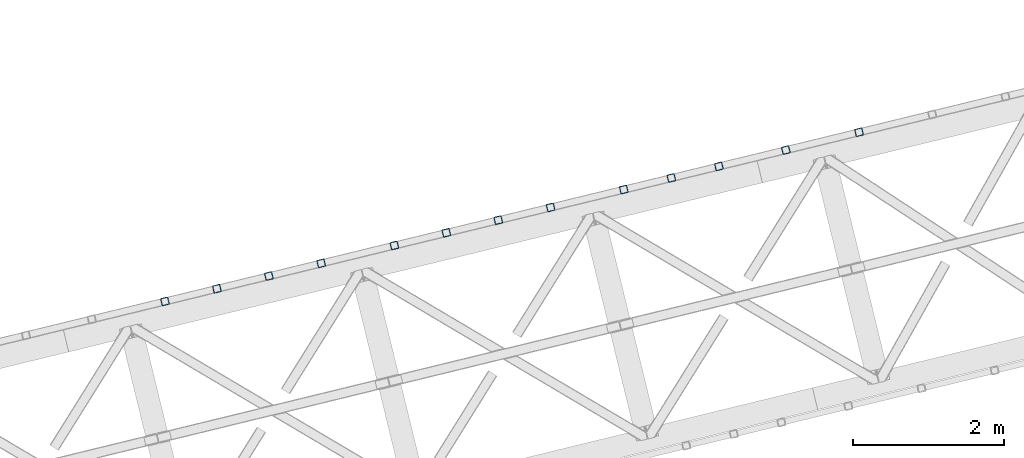
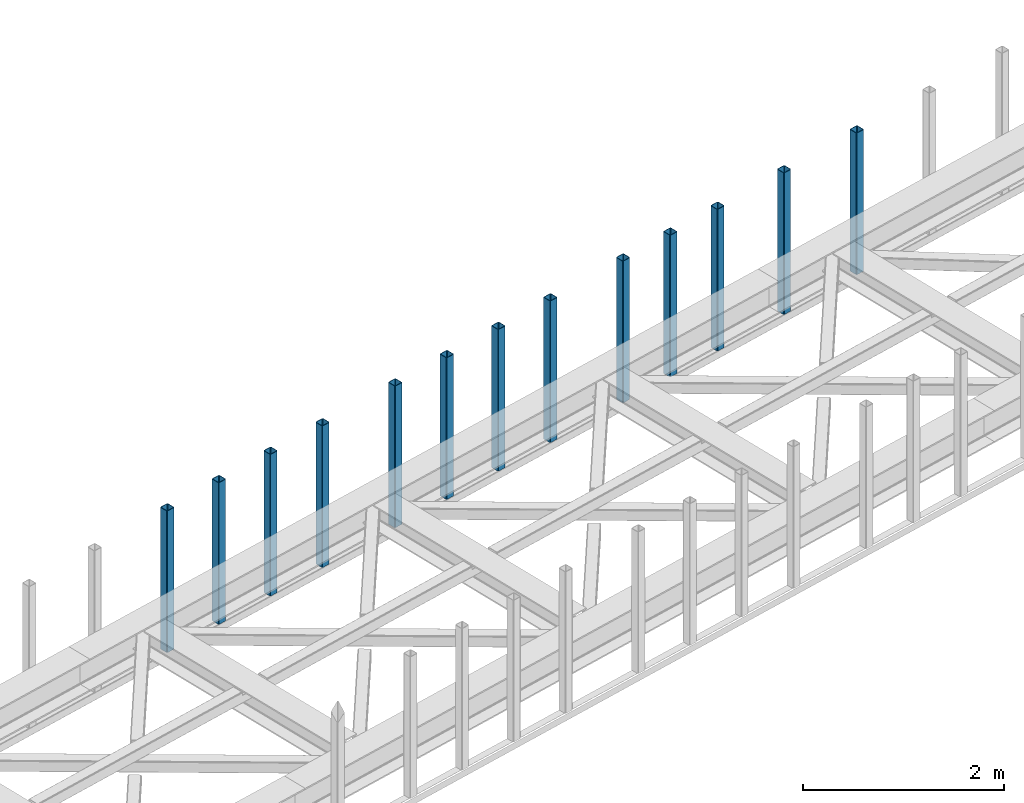
# One storey, part 10 of 67: 13 columns.
"""IFC4 building model written with IfcOpenShell, lengths in millimetres."""

from ifc_helpers import new_model, entity, si_unit, converted_unit, derived_unit, direction, frame, origin, place, context, subcontext, project, spatial, indexed_curve, outline, extrude, type_object, element, save


model = new_model("IFC4")

# Units and contexts
model_context = context("Model", 3, precision=0.01, world=origin(), true_north=direction((6.12303176911189e-17, 1.0)))
plan_context = context("Plan", 3, precision=0.01, world=origin(), true_north=direction((6.12303176911189e-17, 1.0)))
body_context = subcontext(model_context, "Body", "Model", "MODEL_VIEW")
ifc_project = project(units=[si_unit("LENGTHUNIT", "METRE", prefix="MILLI"), si_unit("AREAUNIT", "SQUARE_METRE"), si_unit("VOLUMEUNIT", "CUBIC_METRE"), converted_unit("PLANEANGLEUNIT", "DEGREE", entity("IfcRatioMeasure", 0.0174532925199433), si_unit("PLANEANGLEUNIT", "RADIAN"), dimensions=[0, 0, 0, 0, 0, 0, 0]), si_unit("MASSUNIT", "GRAM", prefix="KILO"), derived_unit("MASSDENSITYUNIT", [(si_unit("MASSUNIT", "GRAM", prefix="KILO"), 1), (si_unit("LENGTHUNIT", "METRE"), -3)]), derived_unit("MOMENTOFINERTIAUNIT", [(si_unit("LENGTHUNIT", "METRE"), 4)]), si_unit("TIMEUNIT", "SECOND"), si_unit("FREQUENCYUNIT", "HERTZ"), si_unit("THERMODYNAMICTEMPERATUREUNIT", "DEGREE_CELSIUS"), derived_unit("THERMALTRANSMITTANCEUNIT", [(si_unit("MASSUNIT", "GRAM", prefix="KILO"), 1), (si_unit("THERMODYNAMICTEMPERATUREUNIT", "KELVIN"), -1), (si_unit("TIMEUNIT", "SECOND"), -3)]), derived_unit("VOLUMETRICFLOWRATEUNIT", [(si_unit("LENGTHUNIT", "METRE"), 3), (si_unit("TIMEUNIT", "SECOND"), -1)]), derived_unit("MASSFLOWRATEUNIT", [(si_unit("MASSUNIT", "GRAM", prefix="KILO"), 1), (si_unit("TIMEUNIT", "SECOND"), -1)]), derived_unit("ROTATIONALFREQUENCYUNIT", [(si_unit("TIMEUNIT", "SECOND"), -1)]), si_unit("ELECTRICCURRENTUNIT", "AMPERE"), si_unit("ELECTRICVOLTAGEUNIT", "VOLT"), si_unit("POWERUNIT", "WATT"), si_unit("FORCEUNIT", "NEWTON", prefix="KILO"), si_unit("ILLUMINANCEUNIT", "LUX"), si_unit("LUMINOUSFLUXUNIT", "LUMEN"), si_unit("LUMINOUSINTENSITYUNIT", "CANDELA"), derived_unit("USERDEFINED", [(si_unit("MASSUNIT", "GRAM", prefix="KILO"), -1), (si_unit("LENGTHUNIT", "METRE"), -2), (si_unit("TIMEUNIT", "SECOND"), 3), (si_unit("LUMINOUSFLUXUNIT", "LUMEN"), 1)]), derived_unit("LINEARVELOCITYUNIT", [(si_unit("LENGTHUNIT", "METRE"), 1), (si_unit("TIMEUNIT", "SECOND"), -1)]), si_unit("PRESSUREUNIT", "PASCAL"), derived_unit("USERDEFINED", [(si_unit("LENGTHUNIT", "METRE"), -2), (si_unit("MASSUNIT", "GRAM", prefix="KILO"), 1), (si_unit("TIMEUNIT", "SECOND"), -2)]), derived_unit("LINEARFORCEUNIT", [(si_unit("MASSUNIT", "GRAM", prefix="KILO"), 1), (si_unit("LENGTHUNIT", "METRE"), 1), (si_unit("TIMEUNIT", "SECOND"), -2), (si_unit("LENGTHUNIT", "METRE"), -1)]), derived_unit("PLANARFORCEUNIT", [(si_unit("MASSUNIT", "GRAM", prefix="KILO"), 1), (si_unit("LENGTHUNIT", "METRE"), 1), (si_unit("TIMEUNIT", "SECOND"), -2), (si_unit("LENGTHUNIT", "METRE"), -2)])], contexts=[model_context, plan_context])

# Site, building, storey
site_placement = place(None, origin())
site = spatial("IfcSite", under=ifc_project, at=site_placement, CompositionType="ELEMENT")
building_placement = place(site_placement, origin())
building = spatial("IfcBuilding", under=site, at=building_placement, CompositionType="ELEMENT")
storey_placement = place(building_placement, frame((0.0, 0.0, 19800.0)))
storey = spatial("IfcBuildingStorey", under=building, at=storey_placement, CompositionType="ELEMENT", Elevation=19800.0)

# Columns
column_type_1 = type_object("IfcColumnType", PredefinedType="COLUMN")
column_1_placement = place(storey_placement, origin())
element("IfcColumn", 1, at=column_1_placement, inside=storey, type_object=column_type_1, ObjectType="Steel Column", PredefinedType="COLUMN", context=body_context, shape_type="SweptSolid", body=[
    extrude(outline(indexed_curve([(29.4768951153467, -56.8428769007942), (33.3787015556676, -56.8428769007942), (36.983500665698, -55.3497202197836), (39.7424944585306, -52.5907264269563), (41.2356511395342, -48.9859273169203), (56.8428769008001, 29.4768951153439), (56.842876900801, 33.3787015556669), (55.3497202197894, 36.9835006657001), (52.5907264269631, 39.7424944585298), (48.985927316928, 41.2356511395354), (-29.4768951153342, 56.8428769008003), (-33.3787015556561, 56.8428769007984), (-36.9835006657031, 55.3497202197932), (-39.7424944585171, 52.5907264269595), (-41.2356511395314, 48.9859273169262), (-56.8428769007964, -29.476895115336), (-56.8428769007886, -33.3787015556607), (-55.3497202197934, -36.9835006656934), (-52.5907264269506, -39.7424944585237), (-48.9859273169156, -41.2356511395292), (29.4768951153467, -56.8428769007942)], self_intersect=False), holes=[indexed_curve([(-43.1065493048213, -37.3071763475937), (-46.7113484148592, -35.8140196665892), (-49.4703422076954, -33.0550258737549), (-50.9634988886935, -29.4502267637184), (-50.9634988887002, -25.5484203234015), (-37.3071763475881, 43.1065493048283), (-35.8140196665894, 46.7113484148641), (-33.0550258737608, 49.4703422076981), (-29.4502267637207, 50.9634988887041), (-25.5484203233977, 50.9634988887032), (43.1065493048309, 37.3071763475988), (46.711348414863, 35.8140196665923), (49.470342207696, 33.0550258737666), (50.9634988887067, 29.4502267637314), (50.9634988887049, 25.5484203234065), (37.3071763475917, -43.1065493048204), (35.8140196665904, -46.7113484148669), (33.0550258737586, -49.4703422076875), (29.4502267637282, -50.9634988886981), (25.5484203234112, -50.9634988886999), (-43.1065493048213, -37.3071763475937)], self_intersect=False)]), frame((-11274.8424574772, 18249.8419278918, 3378.0), z_axis=(0.0, 0.0, 1.0), x_axis=(0.906681479027445, 0.4218159498983, 0.0)), (0.0, 0.0, 1.0), 1720.00000000001),
])
column_type_2 = type_object("IfcColumnType", PredefinedType="COLUMN")
column_2_placement = place(storey_placement, origin())
element("IfcColumn", 2, at=column_2_placement, inside=storey, type_object=column_type_2, ObjectType="Steel Column", PredefinedType="COLUMN", context=body_context, shape_type="SweptSolid", body=[
    extrude(outline(indexed_curve([(29.476895115345, -56.8428769008029), (33.378701555666, -56.8428769008029), (36.9835006657051, -55.3497202197941), (39.7424944585289, -52.590726426965), (41.2356511395325, -48.9859273169291), (56.8428769007984, 29.4768951153351), (56.8428769007993, 33.3787015556581), (55.3497202197965, 36.9835006656896), (52.5907264269614, 39.7424944585211), (48.9859273169264, 41.2356511395266), (-29.4768951153447, 56.8428769007933), (-33.3787015556666, 56.8428769007913), (-36.983500665696, 55.3497202197827), (-39.7424944585188, 52.5907264269508), (-41.2356511395331, 48.9859273169175), (-56.8428769007981, -29.4768951153448), (-56.8428769007903, -33.3787015556695), (-55.3497202197883, -36.983500665703), (-52.5907264269611, -39.7424944585308), (-48.9859273169261, -41.2356511395363), (29.476895115345, -56.8428769008029)], self_intersect=False), holes=[indexed_curve([(-43.106549304823, -37.3071763476025), (-46.7113484148609, -35.814019666598), (-49.4703422076892, -33.0550258737674), (-50.9634988886969, -29.450226763736), (-50.9634988886931, -25.5484203234119), (-37.3071763475889, 43.1065493048215), (-35.8140196665803, 46.7113484148527), (-33.0550258737624, 49.4703422076845), (-29.4502267637223, 50.9634988886953), (-25.5484203233994, 50.9634988886944), (43.1065493048204, 37.3071763475918), (46.7113484148622, 35.8140196665855), (49.4703422076887, 33.0550258737509), (50.9634988887041, 29.4502267637207), (50.9634988887032, 25.5484203233977), (37.3071763475961, -43.1065493048368), (35.8140196665885, -46.711348414866), (33.0550258737647, -49.4703422076999), (29.4502267637178, -50.9634988887051), (25.5484203234007, -50.963498888707), (-43.106549304823, -37.3071763476025)], self_intersect=False)]), frame((-12246.3945156187, 18013.0158349014, 3378.0), z_axis=(0.0, 0.0, 1.0), x_axis=(0.906681479027445, 0.4218159498983, 0.0)), (0.0, 0.0, 1.0), 1720.00000000001),
])
column_type_3 = type_object("IfcColumnType", PredefinedType="COLUMN")
column_3_placement = place(storey_placement, origin())
element("IfcColumn", 3, at=column_3_placement, inside=storey, type_object=column_type_3, ObjectType="Steel Column", PredefinedType="COLUMN", context=body_context, shape_type="SweptSolid", body=[
    extrude(outline(indexed_curve([(29.4768951153135, -56.8428769008188), (33.3787015556354, -56.8428769008188), (36.9835006656656, -55.349720219812), (39.7424944584985, -52.5907264269832), (41.2356511395059, -48.9859273169489), (56.8428769008103, 29.4768951153055), (56.8428769008132, 33.3787015556285), (55.3497202198034, 36.9835006656625), (52.5907264269785, 39.7424944584936), (48.9859273169442, 41.2356511395009), (-29.4768951153102, 56.8428769008053), (-33.3787015556321, 56.8428769008053), (-36.9835006656798, 55.3497202198019), (-39.7424944584943, 52.5907264269716), (-41.2356511395113, 48.9859273169371), (-56.8428769008158, -29.4768951153173), (-56.8428769008099, -33.378701555642), (-55.3497202198166, -36.9835006656754), (-52.5907264269752, -39.7424944585071), (-48.9859273169409, -41.2356511395144), (29.4768951153135, -56.8428769008188)], self_intersect=False), holes=[indexed_curve([(-43.1065493048438, -37.3071763475799), (-46.71134841488, -35.8140196665717), (-49.4703422077156, -33.0550258737379), (-50.963498888712, -29.4502267637007), (-50.9634988887157, -25.5484203233818), (-37.3071763475701, 43.1065493048392), (-35.8140196665686, 46.7113484148762), (-33.0550258737387, 49.4703422077088), (-29.4502267637006, 50.9634988887119), (-25.5484203233757, 50.9634988887081), (43.106549304846, 37.3071763475693), (46.7113484148783, 35.8140196665629), (49.4703422077099, 33.0550258737358), (50.9634988887179, 29.4502267636979), (50.9634988887141, 25.548420323373), (37.3071763475664, -43.106549304847), (35.8140196665642, -46.7113484148908), (33.0550258737309, -49.47034220771), (29.450226763697, -50.9634988887198), (25.5484203233819, -50.9634988887206), (-43.1065493048438, -37.3071763475799)], self_intersect=False)]), frame((-13135.3646488181, 17796.3199598153, 3378.0), z_axis=(0.0, 0.0, 1.0), x_axis=(0.906681479027233, 0.421815949898756, 0.0)), (0.0, 0.0, 1.0), 1720.00000000001),
])
column_type_4 = type_object("IfcColumnType", PredefinedType="COLUMN")
column_4_placement = place(storey_placement, origin())
element("IfcColumn", 4, at=column_4_placement, inside=storey, type_object=column_type_4, ObjectType="Steel Column", PredefinedType="COLUMN", context=body_context, shape_type="SweptSolid", body=[
    extrude(outline(indexed_curve([(29.4768951153144, -56.8428769008169), (33.3787015556363, -56.8428769008168), (36.9835006656743, -55.3497202198137), (39.7424944584907, -52.5907264269795), (41.2356511395068, -48.985927316947), (56.8428769008112, 29.4768951153075), (56.8428769008054, 33.3787015556321), (55.3497202198131, 36.9835006656627), (52.5907264269794, 39.7424944584955), (48.9859273169452, 41.2356511395029), (-29.4768951153093, 56.8428769008073), (-33.3787015556312, 56.8428769008073), (-36.9835006656701, 55.3497202198022), (-39.7424944585022, 52.5907264269753), (-41.2356511395017, 48.9859273169374), (-56.8428769008061, -29.476895115317), (-56.8428769008178, -33.3787015556383), (-55.3497202198089, -36.9835006656742), (-52.5907264269743, -39.7424944585051), (-48.98592731694, -41.2356511395124), (29.4768951153144, -56.8428769008169)], self_intersect=False), holes=[indexed_curve([(-43.1065493048428, -37.3071763475779), (-46.71134841488, -35.8140196665717), (-49.4703422077088, -33.0550258737387), (-50.9634988887127, -29.4502267637075), (-50.963498888707, -25.5484203233835), (-37.3071763475613, 43.1065493048375), (-35.8140196665579, 46.7113484148736), (-33.0550258737472, 49.4703422077008), (-29.4502267636997, 50.9634988887139), (-25.5484203233748, 50.9634988887101), (43.1065493048469, 37.3071763475713), (46.7113484148862, 35.8140196665592), (49.4703422077099, 33.0550258737358), (50.9634988887101, 29.4502267636967), (50.963498888715, 25.5484203233749), (37.3071763475673, -43.1065493048451), (35.8140196665648, -46.7113484148792), (33.0550258737388, -49.4703422077137), (29.4502267636979, -50.9634988887178), (25.5484203233828, -50.9634988887186), (-43.1065493048428, -37.3071763475779)], self_intersect=False)]), frame((-13766.8734866101, 17642.3829993716, 3378.0), z_axis=(0.0, 0.0, 1.0), x_axis=(0.906681479027233, 0.421815949898756, 0.0)), (0.0, 0.0, 1.0), 1720.00000000001),
])
column_type_5 = type_object("IfcColumnType", PredefinedType="COLUMN")
column_5_placement = place(storey_placement, origin())
element("IfcColumn", 5, at=column_5_placement, inside=storey, type_object=column_type_5, ObjectType="Steel Column", PredefinedType="COLUMN", context=body_context, shape_type="SweptSolid", body=[
    extrude(outline(indexed_curve([(29.4768951153174, -56.8428769008206), (33.3787015556393, -56.8428769008206), (36.9835006656686, -55.3497202198158), (39.7424944584928, -52.5907264269853), (41.2356511395098, -48.9859273169507), (56.8428769008143, 29.4768951153037), (56.8428769008084, 33.3787015556284), (55.3497202198073, 36.9835006656606), (52.5907264269824, 39.7424944584918), (48.9859273169482, 41.2356511394991), (-29.4768951153063, 56.8428769008035), (-33.3787015556282, 56.8428769008035), (-36.9835006656671, 55.3497202197984), (-39.742494458502, 52.5907264269705), (-41.2356511395162, 48.985927316937), (-56.8428769008207, -29.4768951153174), (-56.8428769008148, -33.3787015556421), (-55.3497202198059, -36.9835006656781), (-52.5907264269713, -39.7424944585089), (-48.985927316939, -41.2356511395153), (29.4768951153174, -56.8428769008206)], self_intersect=False), holes=[indexed_curve([(-43.1065493048398, -37.3071763475817), (-46.71134841487, -35.8140196665811), (-49.4703422077058, -33.0550258737425), (-50.9634988887097, -29.4502267637113), (-50.9634988887049, -25.5484203233892), (-37.3071763475583, 43.1065493048337), (-35.8140196665549, 46.7113484148698), (-33.0550258737372, 49.4703422076914), (-29.4502267636888, 50.9634988887065), (-25.5484203233718, 50.9634988887063), (43.1065493048578, 37.3071763475638), (46.7113484148892, 35.8140196665554), (49.470342207712, 33.0550258737301), (50.963498888721, 29.4502267636893), (50.963498888718, 25.5484203233712), (37.3071763475782, -43.1065493048525), (35.8140196665669, -46.7113484148849), (33.0550258737409, -49.4703422077194), (29.4502267637087, -50.9634988887253), (25.5484203233858, -50.9634988887224), (-43.1065493048398, -37.3071763475817)], self_intersect=False)]), frame((-14398.382324402, 17488.4460389278, 3378.0), z_axis=(0.0, 0.0, 1.0), x_axis=(0.906681479027233, 0.421815949898756, 0.0)), (0.0, 0.0, 1.0), 1720.00000000001),
])
column_type_6 = type_object("IfcColumnType", PredefinedType="COLUMN")
column_6_placement = place(storey_placement, origin())
element("IfcColumn", 6, at=column_6_placement, inside=storey, type_object=column_type_6, ObjectType="Steel Column", PredefinedType="COLUMN", context=body_context, shape_type="SweptSolid", body=[
    extrude(outline(indexed_curve([(29.4768951153084, -56.8428769008093), (33.3787015556303, -56.8428769008093), (36.9835006656771, -55.3497202198078), (39.7424944585013, -52.5907264269773), (41.2356511395008, -48.9859273169394), (56.8428769008052, 29.4768951153151), (56.8428769008169, 33.3787015556363), (55.3497202198158, 36.9835006656686), (52.5907264269734, 39.7424944585031), (48.9859273169391, 41.2356511395105), (-29.4768951153065, 56.8428769008132), (-33.3787015556284, 56.8428769008132), (-36.9835006656674, 55.3497202198081), (-39.7424944584936, 52.5907264269785), (-41.2356511394989, 48.9859273169433), (-56.8428769008034, -29.4768951153111), (-56.8428769008063, -33.3787015556341), (-55.3497202198062, -36.9835006656684), (-52.5907264269716, -39.7424944584992), (-48.9859273169373, -41.2356511395065), (29.4768951153084, -56.8428769008093)], self_intersect=False), holes=[indexed_curve([(-43.1065493048498, -37.3071763475723), (-46.7113484148745, -35.8140196665599), (-49.470342207706, -33.0550258737377), (-50.9634988887109, -29.4502267637035), (-50.9634988887052, -25.5484203233795), (-37.3071763475604, 43.1065493048394), (-35.814019666556, 46.7113484148775), (-33.0550258737298, 49.4703422077023), (-29.4502267636977, 50.963498888713), (-25.5484203233817, 50.9634988887157), (43.1065493048566, 37.3071763475716), (46.711348414888, 35.8140196665631), (49.4703422077176, 33.055025873737), (50.9634988887286, 29.4502267636953), (50.9634988887247, 25.5484203233752), (37.307176347577, -43.1065493048448), (35.8140196665736, -46.7113484148809), (33.0550258737302, -49.4703422077168), (29.4502267637076, -50.9634988887176), (25.5484203233846, -50.9634988887147), (-43.1065493048498, -37.3071763475723)], self_intersect=False)]), frame((-15369.9343825435, 17251.6199459375, 3378.0), z_axis=(0.0, 0.0, 1.0), x_axis=(0.906681479027233, 0.421815949898756, 0.0)), (0.0, 0.0, 1.0), 1720.00000000001),
])
column_type_7 = type_object("IfcColumnType", PredefinedType="COLUMN")
column_7_placement = place(storey_placement, origin())
element("IfcColumn", 7, at=column_7_placement, inside=storey, type_object=column_type_7, ObjectType="Steel Column", PredefinedType="COLUMN", context=body_context, shape_type="SweptSolid", body=[
    extrude(outline(indexed_curve([(29.4768951153124, -56.8428769008159), (33.3787015556343, -56.8428769008159), (36.9835006656733, -55.3497202198108), (39.7424944584907, -52.5907264269795), (41.2356511395048, -48.985927316946), (56.8428769008093, 29.4768951153084), (56.8428769008034, 33.378701555633), (55.3497202198111, 36.9835006656636), (52.5907264269774, 39.7424944584964), (48.9859273169432, 41.2356511395038), (-29.4768951153112, 56.8428769008082), (-33.3787015556332, 56.8428769008082), (-36.9835006656721, 55.3497202198031), (-39.7424944585041, 52.5907264269762), (-41.2356511395036, 48.9859273169383), (-56.8428769008081, -29.4768951153161), (-56.8428769008197, -33.3787015556374), (-55.3497202198109, -36.9835006656733), (-52.5907264269763, -39.7424944585042), (-48.985927316942, -41.2356511395115), (29.4768951153124, -56.8428769008159)], self_intersect=False), holes=[indexed_curve([(-43.1065493048457, -37.307176347579), (-46.7113484148829, -35.8140196665727), (-49.4703422077117, -33.0550258737397), (-50.9634988887156, -29.4502267637085), (-50.9634988887099, -25.5484203233845), (-37.3071763475642, 43.1065493048364), (-35.8140196665607, 46.7113484148725), (-33.05502587375, 49.4703422076998), (-29.4502267637026, 50.9634988887129), (-25.5484203233777, 50.9634988887091), (43.106549304844, 37.3071763475702), (46.7113484148833, 35.8140196665582), (49.470342207707, 33.0550258737348), (50.9634988887073, 29.4502267636957), (50.9634988887121, 25.5484203233739), (37.3071763475644, -43.1065493048461), (35.8140196665619, -46.7113484148802), (33.0550258737359, -49.4703422077147), (29.450226763695, -50.9634988887189), (25.5484203233799, -50.9634988887197), (-43.1065493048457, -37.307176347579)], self_intersect=False)]), frame((-16064.5941041146, 17082.2892894494, 3378.0), z_axis=(0.0, 0.0, 1.0), x_axis=(0.906681479027233, 0.421815949898756, 0.0)), (0.0, 0.0, 1.0), 1720.00000000001),
])
column_type_8 = type_object("IfcColumnType", PredefinedType="COLUMN")
column_8_placement = place(storey_placement, origin())
element("IfcColumn", 8, at=column_8_placement, inside=storey, type_object=column_type_8, ObjectType="Steel Column", PredefinedType="COLUMN", context=body_context, shape_type="SweptSolid", body=[
    extrude(outline(indexed_curve([(29.4768951153162, -56.8428769008129), (33.3787015556381, -56.8428769008129), (36.9835006656595, -55.3497202198045), (39.7424944585004, -52.5907264269793), (41.2356511395086, -48.985927316943), (56.8428769008131, 29.4768951153114), (56.842876900816, 33.3787015556344), (55.3497202197974, 36.98350066567), (52.5907264269812, 39.7424944584995), (48.985927316947, 41.2356511395068), (-29.4768951153162, 56.8428769008129), (-33.3787015556381, 56.8428769008129), (-36.9835006656683, 55.3497202198061), (-39.7424944584945, 52.5907264269765), (-41.2356511395086, 48.985927316943), (-56.8428769008131, -29.4768951153114), (-56.8428769008072, -33.3787015556361), (-55.3497202198071, -36.9835006656703), (-52.5907264269812, -39.7424944584995), (-48.985927316947, -41.2356511395068), (29.4768951153162, -56.8428769008129)], self_intersect=False), holes=[indexed_curve([(-43.106549304841, -37.307176347574), (-46.7113484148703, -35.8140196665714), (-49.4703422077051, -33.0550258737357), (-50.9634988887109, -29.4502267637035), (-50.9634988887052, -25.5484203233795), (-37.3071763475664, 43.106549304847), (-35.8140196665551, 46.7113484148795), (-33.0550258737289, 49.4703422077042), (-29.45022676369, 50.9634988887142), (-25.548420323373, 50.963498888714), (43.1065493048478, 37.3071763475732), (46.711348414881, 35.8140196665688), (49.4703422077149, 33.0550258737311), (50.9634988887286, 29.4502267636953), (50.9634988887247, 25.5484203233752), (37.307176347583, -43.1065493048524), (35.8140196665745, -46.7113484148789), (33.0550258737406, -49.4703422077097), (29.4502267637008, -50.9634988887168), (25.5484203233758, -50.963498888713), (-43.106549304841, -37.307176347574)], self_intersect=False)]), frame((-16754.3960653951, 16914.1427634263, 3378.0), z_axis=(0.0, 0.0, 1.0), x_axis=(0.906681479027233, 0.421815949898756, 0.0)), (0.0, 0.0, 1.0), 1720.00000000001),
])
column_type_9 = type_object("IfcColumnType", PredefinedType="COLUMN")
column_9_placement = place(storey_placement, origin())
element("IfcColumn", 9, at=column_9_placement, inside=storey, type_object=column_type_9, ObjectType="Steel Column", PredefinedType="COLUMN", context=body_context, shape_type="SweptSolid", body=[
    extrude(outline(indexed_curve([(29.4768951153152, -56.84287690081), (33.3787015556371, -56.84287690081), (36.9835006656751, -55.3497202198069), (39.7424944584993, -52.5907264269764), (41.2356511395076, -48.9859273169401), (56.842876900812, 29.4768951153143), (56.8428769008149, 33.3787015556372), (55.3497202198139, 36.9835006656695), (52.5907264269802, 39.7424944585023), (48.9859273169459, 41.2356511395097), (-29.4768951153173, 56.8428769008158), (-33.3787015556392, 56.8428769008158), (-36.9835006656694, 55.349720219809), (-39.7424944584955, 52.5907264269794), (-41.2356511395097, 48.9859273169459), (-56.8428769008141, -29.4768951153085), (-56.8428769008082, -33.3787015556332), (-55.3497202198081, -36.9835006656674), (-52.5907264269823, -39.7424944584966), (-48.985927316948, -41.2356511395039), (29.4768951153152, -56.84287690081)], self_intersect=False), holes=[indexed_curve([(-43.106549304843, -37.3071763475731), (-46.7113484148792, -35.8140196665648), (-49.470342207707, -33.0550258737348), (-50.9634988887129, -29.4502267637026), (-50.9634988887071, -25.5484203233786), (-37.3071763475684, 43.106549304848), (-35.8140196665571, 46.7113484148804), (-33.0550258737387, 49.4703422077088), (-29.450226763692, 50.9634988887151), (-25.5484203233749, 50.963498888715), (43.1065493048459, 37.3071763475742), (46.71134841488, 35.8140196665717), (49.4703422077041, 33.0550258737337), (50.9634988887188, 29.4502267636999), (50.9634988887157, 25.5484203233818), (37.3071763475732, -43.1065493048478), (35.8140196665647, -46.7113484148743), (33.0550258737396, -49.4703422077069), (29.4502267636988, -50.9634988887159), (25.5484203233739, -50.9634988887121), (-43.106549304843, -37.3071763475731)], self_intersect=False)]), frame((-17444.1980266755, 16745.9962374031, 3378.0), z_axis=(0.0, 0.0, 1.0), x_axis=(0.906681479027233, 0.421815949898756, 0.0)), (0.0, 0.0, 1.0), 1720.00000000001),
])
column_type_10 = type_object("IfcColumnType", PredefinedType="COLUMN")
column_10_placement = place(storey_placement, origin())
element("IfcColumn", 10, at=column_10_placement, inside=storey, type_object=column_type_10, ObjectType="Steel Column", PredefinedType="COLUMN", context=body_context, shape_type="SweptSolid", body=[
    extrude(outline(indexed_curve([(29.4768951153135, -56.8428769008188), (33.3787015556354, -56.8428769008188), (36.9835006656656, -55.349720219812), (39.7424944584985, -52.5907264269832), (41.2356511395059, -48.9859273169489), (56.8428769008103, 29.4768951153055), (56.8428769008132, 33.3787015556285), (55.3497202198034, 36.9835006656625), (52.5907264269785, 39.7424944584936), (48.9859273169442, 41.2356511395009), (-29.4768951153102, 56.8428769008053), (-33.3787015556321, 56.8428769008053), (-36.9835006656798, 55.3497202198019), (-39.7424944584943, 52.5907264269716), (-41.2356511395113, 48.9859273169371), (-56.8428769008158, -29.4768951153173), (-56.8428769008099, -33.378701555642), (-55.3497202198166, -36.9835006656754), (-52.5907264269752, -39.7424944585071), (-48.9859273169409, -41.2356511395144), (29.4768951153135, -56.8428769008188)], self_intersect=False), holes=[indexed_curve([(-43.1065493048438, -37.3071763475799), (-46.7113484148721, -35.8140196665753), (-49.4703422077078, -33.0550258737416), (-50.9634988887041, -29.4502267637043), (-50.9634988887079, -25.5484203233854), (-37.3071763475622, 43.1065493048355), (-35.8140196665607, 46.7113484148725), (-33.0550258737308, 49.4703422077052), (-29.4502267636928, 50.9634988887083), (-25.5484203233757, 50.9634988887081), (43.1065493048539, 37.3071763475657), (46.7113484148862, 35.8140196665592), (49.4703422077177, 33.0550258737322), (50.9634988887257, 29.4502267636943), (50.9634988887219, 25.5484203233694), (37.3071763475743, -43.1065493048507), (35.814019666572, -46.7113484148945), (33.0550258737388, -49.4703422077136), (29.4502267637048, -50.9634988887234), (25.5484203233819, -50.9634988887206), (-43.1065493048438, -37.3071763475799)], self_intersect=False)]), frame((-18415.750084817, 16509.1701444128, 3378.0), z_axis=(0.0, 0.0, 1.0), x_axis=(0.906681479027233, 0.421815949898756, 0.0)), (0.0, 0.0, 1.0), 1720.00000000001),
])
column_type_11 = type_object("IfcColumnType", PredefinedType="COLUMN")
column_11_placement = place(storey_placement, origin())
element("IfcColumn", 11, at=column_11_placement, inside=storey, type_object=column_type_11, ObjectType="Steel Column", PredefinedType="COLUMN", context=body_context, shape_type="SweptSolid", body=[
    extrude(outline(indexed_curve([(29.4768951153094, -56.8428769008122), (33.3787015556313, -56.8428769008121), (36.9835006656703, -55.3497202198071), (39.7424944585032, -52.5907264269782), (41.2356511395018, -48.9859273169423), (56.8428769008082, 29.4768951153113), (56.8428769008179, 33.3787015556334), (55.3497202198081, 36.9835006656674), (52.5907264269744, 39.7424944585002), (48.9859273169402, 41.2356511395076), (-29.4768951153055, 56.8428769008103), (-33.3787015556274, 56.8428769008103), (-36.9835006656664, 55.3497202198052), (-39.7424944584896, 52.5907264269767), (-41.2356511395066, 48.9859273169421), (-56.8428769008111, -29.4768951153123), (-56.8428769008052, -33.378701555637), (-55.3497202198051, -36.9835006656712), (-52.5907264269705, -39.7424944585021), (-48.9859273169363, -41.2356511395094), (29.4768951153094, -56.8428769008122)], self_intersect=False), holes=[indexed_curve([(-43.1065493048478, -37.3071763475732), (-46.7113484148804, -35.8140196665571), (-49.4703422077119, -33.0550258737349), (-50.9634988887168, -29.4502267637008), (-50.963498888711, -25.5484203233768), (-37.3071763475663, 43.1065493048422), (-35.8140196665619, 46.7113484148802), (-33.0550258737357, 49.470342207705), (-29.4502267637036, 50.9634988887157), (-25.5484203233798, 50.9634988887148), (43.1065493048507, 37.3071763475743), (46.7113484148821, 35.8140196665659), (49.4703422077117, 33.0550258737397), (50.9634988887227, 29.450226763698), (50.9634988887188, 25.548420323378), (37.3071763475711, -43.1065493048421), (35.8140196665677, -46.7113484148782), (33.0550258737243, -49.4703422077141), (29.4502267637017, -50.9634988887148), (25.5484203233866, -50.9634988887156), (-43.1065493048478, -37.3071763475732)], self_intersect=False)]), frame((-19110.4098063882, 16339.8394879247, 3378.0), z_axis=(0.0, 0.0, 1.0), x_axis=(0.906681479027233, 0.421815949898756, 0.0)), (0.0, 0.0, 1.0), 1720.00000000001),
])
column_type_12 = type_object("IfcColumnType", PredefinedType="COLUMN")
column_12_placement = place(storey_placement, origin())
element("IfcColumn", 12, at=column_12_placement, inside=storey, type_object=column_type_12, ObjectType="Steel Column", PredefinedType="COLUMN", context=body_context, shape_type="SweptSolid", body=[
    extrude(outline(indexed_curve([(29.4768951152999, -56.8428769008161), (33.3787015556198, -56.8428769008161), (36.9835006656602, -55.3497202198147), (39.742494458485, -52.5907264269848), (41.2356511395009, -48.9859273169497), (56.8428769008257, 29.4768951153002), (56.8428769008208, 33.3787015556248), (55.3497202198186, 36.9835006656584), (52.5907264269856, 39.7424944584918), (48.9859273169556, 41.2356511394982), (-29.4768951153059, 56.8428769008236), (-33.3787015556259, 56.8428769008236), (-36.9835006656496, 55.3497202198169), (-39.7424944584832, 52.5907264269887), (-41.2356511395021, 48.9859273169574), (-56.842876900823, -29.4768951152943), (-56.842876900818, -33.3787015556189), (-55.349720219808, -36.9835006656561), (-52.5907264269955, -39.7424944584824), (-48.9859273169616, -41.2356511394906), (29.4768951152999, -56.8428769008161)], self_intersect=False), holes=[indexed_curve([(-43.1065493048547, -37.3071763475592), (-46.7113484148799, -35.8140196665527), (-49.4703422077072, -33.0550258737171), (-50.9634988887208, -29.4502267636878), (-50.9634988887161, -25.5484203233628), (-37.3071763475593, 43.1065493048596), (-35.8140196665471, 46.7113484148868), (-33.0550258737232, 49.4703422077148), (-29.4502267636791, 50.963498888724), (-25.548420323364, 50.9634988887238), (43.1065493048536, 37.3071763475669), (46.7113484148854, 35.8140196665645), (49.4703422077293, 33.0550258737236), (50.9634988887305, 29.450226763688), (50.9634988887276, 25.548420323367), (37.3071763475699, -43.1065493048573), (35.8140196665616, -46.7113484148864), (33.0550258737338, -49.4703422077125), (29.4502267636819, -50.9634988887181), (25.5484203233589, -50.9634988887143), (-43.1065493048547, -37.3071763475592)], self_intersect=False)]), frame((-19800.2117676686, 16171.6929619016, 3378.0), z_axis=(0.0, 0.0, 1.0), x_axis=(0.906681479027134, 0.421815949898968, 0.0)), (0.0, 0.0, 1.0), 1720.00000000001),
])
column_type_13 = type_object("IfcColumnType", PredefinedType="COLUMN")
column_13_placement = place(storey_placement, origin())
element("IfcColumn", 13, at=column_13_placement, inside=storey, type_object=column_type_13, ObjectType="Steel Column", PredefinedType="COLUMN", context=body_context, shape_type="SweptSolid", body=[
    extrude(outline(indexed_curve([(29.476895115302, -56.8428769008218), (33.3787015556219, -56.8428769008218), (36.9835006656544, -55.3497202198168), (39.7424944584793, -52.5907264269869), (41.2356511394982, -48.9859273169556), (56.8428769008191, 29.4768951152961), (56.8428769008141, 33.3787015556208), (55.349720219812, 36.9835006656543), (52.5907264269916, 39.7424944584843), (48.9859273169577, 41.2356511394924), (-29.476895115295, 56.8428769008162), (-33.378701555615, 56.8428769008162), (-36.9835006656563, 55.3497202198129), (-39.742494458489, 52.5907264269866), (-41.2356511395049, 48.9859273169515), (-56.8428769008297, -29.4768951152983), (-56.8428769008247, -33.378701555623), (-55.3497202198147, -36.9835006656602), (-52.5907264269847, -39.7424944584899), (-48.9859273169507, -41.2356511394981), (29.476895115302, -56.8428769008218)], self_intersect=False), holes=[indexed_curve([(-43.1065493048536, -37.3071763475669), (-46.7113484148884, -35.8140196665607), (-49.4703422077166, -33.0550258737271), (-50.9634988887196, -29.4502267636955), (-50.9634988887149, -25.5484203233706), (-37.3071763475512, 43.1065493048462), (-35.8140196665489, 46.7113484148829), (-33.0550258737395, 49.4703422077104), (-29.4502267636858, 50.9634988887199), (-25.5484203233628, 50.9634988887161), (43.1065493048557, 37.3071763475612), (46.7113484148926, 35.8140196665492), (49.4703422077157, 33.0550258737251), (50.963498888719, 29.4502267636838), (50.963498888721, 25.548420323363), (37.3071763475572, -43.1065493048538), (35.8140196665519, -46.7113484148867), (33.0550258737253, -49.4703422077205), (29.450226763684, -50.9634988887238), (25.5484203233689, -50.9634988887237), (-43.1065493048536, -37.3071763475669)], self_intersect=False)]), frame((-20490.013728949, 16003.5464358784, 3378.0), z_axis=(0.0, 0.0, 1.0), x_axis=(0.906681479027134, 0.421815949898968, 0.0)), (0.0, 0.0, 1.0), 1720.00000000001),
])

save(model, "model.ifc")
